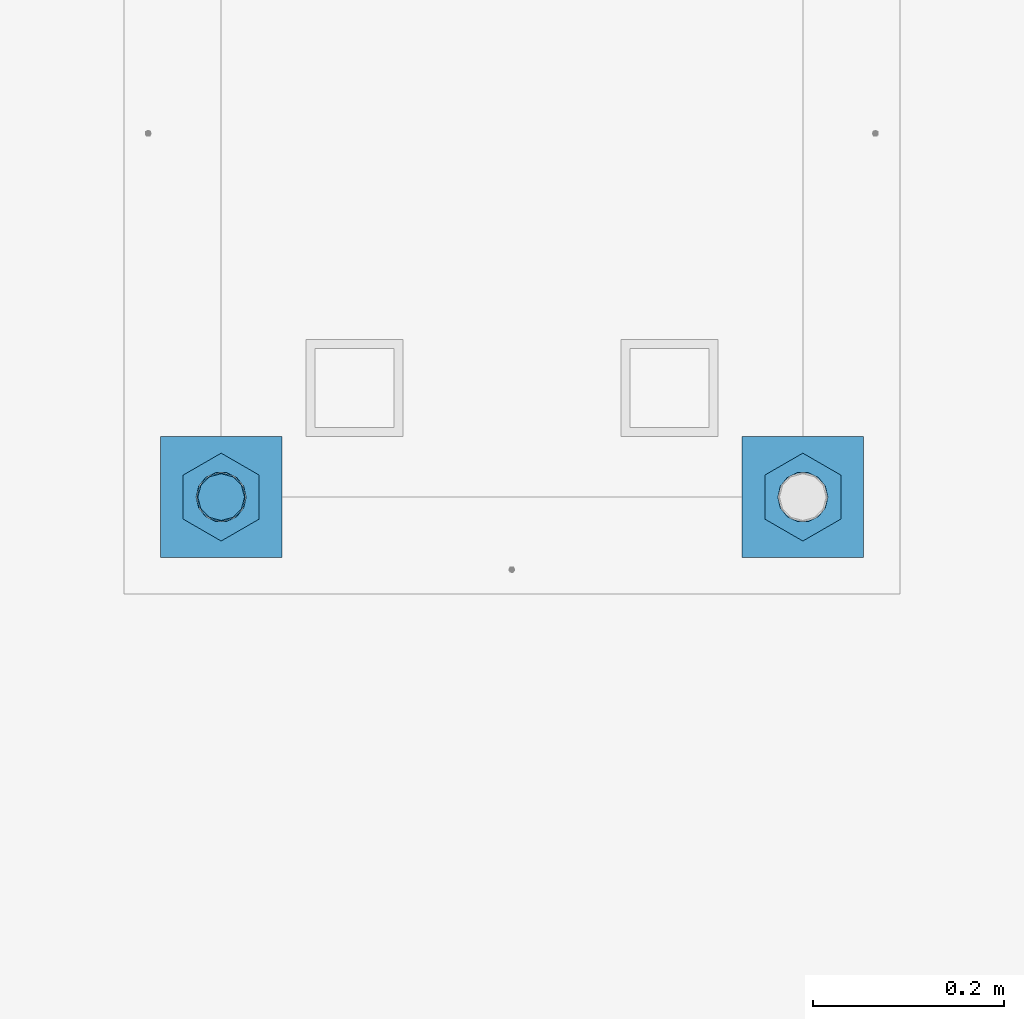
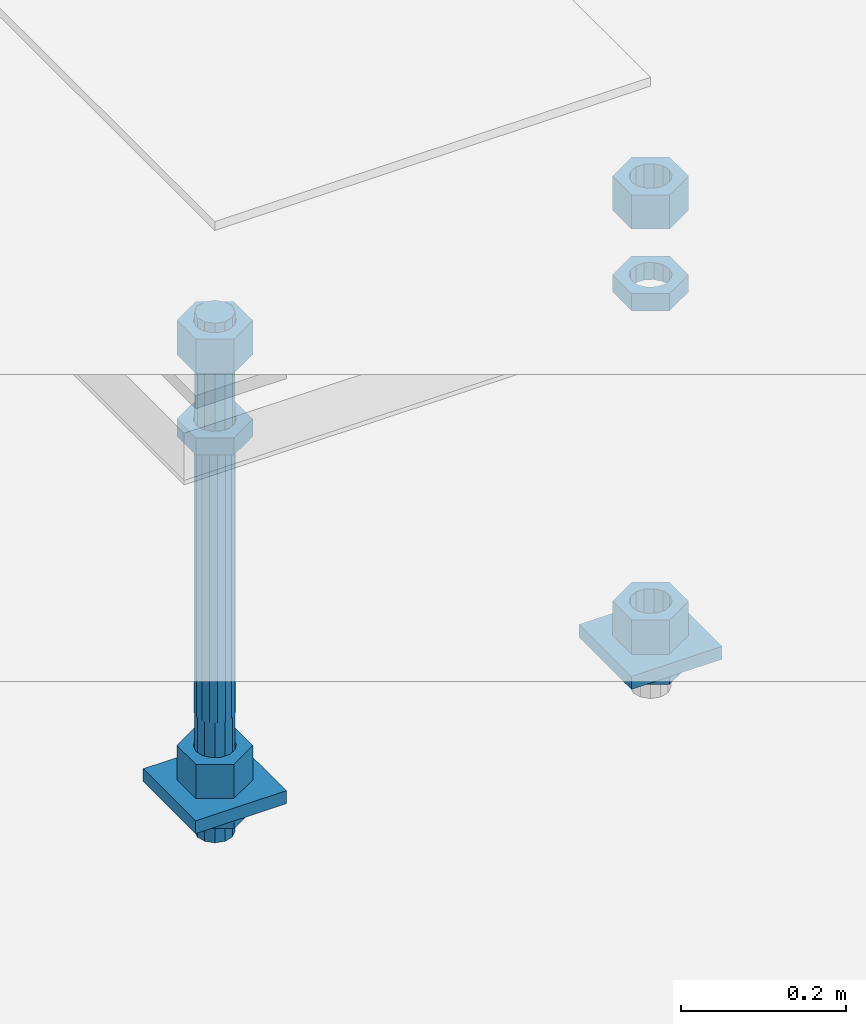
# One storey, part 2628 of 3843: 11 beams, 1 element without a shape of its own.
"""IFC2X3 building model written with IfcOpenShell, lengths in millimetres."""

from ifc_helpers import new_model, si_unit, frame, origin_with_axes, place, context, subcontext, project, spatial, faceted_brep, material, type_object, element, aggregate, save


model = new_model("IFC2X3")

# Units and contexts
model_context = context("Model", 3, precision=1e-05, world=origin_with_axes())
body_context = subcontext(model_context, "Body", "Model", "MODEL_VIEW")
ifc_project = project(units=[si_unit("LENGTHUNIT", "METRE", prefix="MILLI"), si_unit("AREAUNIT", "SQUARE_METRE"), si_unit("VOLUMEUNIT", "CUBIC_METRE"), si_unit("MASSUNIT", "GRAM", prefix="KILO"), si_unit("TIMEUNIT", "SECOND"), si_unit("PLANEANGLEUNIT", "RADIAN"), si_unit("SOLIDANGLEUNIT", "STERADIAN"), si_unit("THERMODYNAMICTEMPERATUREUNIT", "DEGREE_CELSIUS"), si_unit("LUMINOUSINTENSITYUNIT", "LUMEN")], contexts=[model_context])

# Site, building, storey
site_placement = place(None, origin_with_axes())
site = spatial("IfcSite", under=ifc_project, at=site_placement, CompositionType="ELEMENT")
building_placement = place(site_placement, origin_with_axes())
building = spatial("IfcBuilding", under=site, at=building_placement, Name="Undefined", CompositionType="ELEMENT")
storey_placement = place(building_placement, origin_with_axes())
storey = spatial("IfcBuildingStorey", under=building, at=storey_placement, Name="Undefined", CompositionType="ELEMENT", Elevation=0.0)

# Assembly, beams
assembly_placement = place(storey_placement, origin_with_axes())
assembly = element("IfcElementAssembly", 1, at=assembly_placement, inside=storey, Name="TEMPLATE", AssemblyPlace="NOTDEFINED", PredefinedType="RIGID_FRAME")
ifc_material_1 = material(Name="STEEL/A36")
beam_type_1 = type_object("IfcBeamType", PredefinedType="NOTDEFINED")
beam_1_placement = place(assembly_placement, frame((115862.099998474, 7073.90000000001, 29244.925), z_axis=(0.0, 1.0, 0.0), x_axis=(-1.0, 0.0, 0.0)))
beam_1 = element("IfcBeam", 2, at=beam_1_placement, type_object=beam_type_1, material=ifc_material_1, Name="WASHER_PLATE", context=body_context, shape_type="Brep", body=[
    faceted_brep([(0.0, 9.52500000000146, -63.5), (0.0, 9.52500000000146, 63.5), (127.0, 9.52500000000146, 63.5), (127.0, 9.52500000000146, -63.5), (0.0, -9.52500000000146, 63.5), (127.0, -9.52500000000146, 63.5), (0.0, -9.52500000000146, -63.5), (127.0, -9.52500000000146, -63.5)], [[[0, 1, 2, 3]], [[1, 4, 5, 2]], [[4, 6, 7, 5]], [[6, 0, 3, 7]], [[5, 7, 3, 2]], [[6, 4, 1, 0]]]),
])
beam_2_placement = place(assembly_placement, frame((116471.7, 7073.90000000001, 29244.925), z_axis=(0.0, 1.0, 0.0), x_axis=(-1.0, 0.0, 0.0)))
beam_2 = element("IfcBeam", 3, at=beam_2_placement, type_object=beam_type_1, material=ifc_material_1, Name="WASHER_PLATE", context=body_context, shape_type="Brep", body=[
    faceted_brep([(0.0, 9.52500000000146, -63.5), (0.0, 9.52500000000146, 63.5), (127.0, 9.52500000000146, 63.5), (127.0, 9.52500000000146, -63.5), (0.0, -9.52500000000146, 63.5), (127.0, -9.52500000000146, 63.5), (0.0, -9.52500000000146, -63.5), (127.0, -9.52500000000146, -63.5)], [[[0, 1, 2, 3]], [[1, 4, 5, 2]], [[4, 6, 7, 5]], [[6, 0, 3, 7]], [[5, 7, 3, 2]], [[6, 4, 1, 0]]]),
])
beam_type_2 = type_object("IfcBeamType", Name="2_HALF_NUT", PredefinedType="NOTDEFINED")
beam_3_placement = place(assembly_placement, frame((115798.599998474, 7073.90000000001, 29787.85), z_axis=(-1.0, 0.0, 0.0), x_axis=(0.0, 0.0, -1.0)))
beam_3 = element("IfcBeam", 4, at=beam_3_placement, type_object=beam_type_2, material=ifc_material_1, Name="NUT", ObjectType="2_HALF_NUT", context=body_context, shape_type="Brep", body=[
    faceted_brep([(0.0, -46.0369987487793, 0.0), (0.0, -23.0184993743896, -39.869213104248), (25.4000000000015, -23.0184993743896, -39.869213104248), (25.4000000000015, -46.0369987487793, 0.0), (0.0, 23.0184993743896, -39.869213104248), (25.4000000000015, 23.0184993743896, -39.869213104248), (0.0, 46.0369987487793, 0.0), (25.4000000000015, 46.0369987487793, 0.0), (0.0, 23.0184993743896, 39.869213104248), (25.4000000000015, 23.0184993743896, 39.869213104248), (0.0, -23.0184993743896, 39.869213104248), (25.4000000000015, -23.0184993743896, 39.869213104248), (0.0, 0.0, 26.1940002441406), (0.0, 11.3650617044477, 23.5999013092805), (25.4000000000015, 11.3650617044477, 23.5999013092805), (25.4000000000015, 0.0, 26.1940002441406), (0.0, 20.4791109456419, 16.3316083006721), (25.4000000000015, 20.4791109456419, 16.3316083006721), (0.0, 25.5370200498292, 5.82867859874386), (25.4000000000015, 25.5370200498292, 5.82867859874386), (0.0, 25.5370200498292, -5.82867859874386), (25.4000000000015, 25.5370200498292, -5.82867859874386), (0.0, 20.4791109456419, -16.3316083006721), (25.4000000000015, 20.4791109456419, -16.3316083006721), (0.0, 11.3650617044477, -23.5999013092805), (25.4000000000015, 11.3650617044477, -23.5999013092805), (0.0, 0.0, -26.1940002441406), (25.4000000000015, 0.0, -26.1940002441406), (0.0, -11.3650617044477, -23.5999013092805), (25.4000000000015, -11.3650617044477, -23.5999013092805), (0.0, -20.4791109456419, -16.3316083006721), (25.4000000000015, -20.4791109456419, -16.3316083006721), (0.0, -25.5370200498292, -5.82867859874386), (25.4000000000015, -25.5370200498292, -5.82867859874386), (0.0, -25.5370200498292, 5.82867859874386), (25.4000000000015, -25.5370200498292, 5.82867859874386), (0.0, -20.4791109456419, 16.3316083006721), (25.4000000000015, -20.4791109456419, 16.3316083006721), (0.0, -11.3650617044477, 23.5999013092805), (25.4000000000015, -11.3650617044477, 23.5999013092805)], [[[0, 1, 2, 3]], [[1, 4, 5, 2]], [[4, 6, 7, 5]], [[6, 8, 9, 7]], [[8, 10, 11, 9]], [[10, 0, 3, 11]], [[12, 13, 14, 15]], [[13, 16, 17, 14]], [[16, 18, 19, 17]], [[18, 20, 21, 19]], [[20, 22, 23, 21]], [[22, 24, 25, 23]], [[24, 26, 27, 25]], [[26, 28, 29, 27]], [[28, 30, 31, 29]], [[30, 32, 33, 31]], [[32, 34, 35, 33]], [[34, 36, 37, 35]], [[36, 38, 39, 37]], [[38, 12, 15, 39]], [[5, 7, 9, 11, 3, 2], [17, 19, 21, 23, 25, 27, 29, 31, 33, 35, 37, 39, 15, 14]], [[10, 8, 6, 4, 1, 0], [38, 36, 34, 32, 30, 28, 26, 24, 22, 20, 18, 16, 13, 12]]]),
])
beam_4_placement = place(assembly_placement, frame((115798.599998474, 7073.9, 29235.4), z_axis=(-1.0, 0.0, 0.0), x_axis=(0.0, 0.0, -1.0)))
beam_4 = element("IfcBeam", 5, at=beam_4_placement, type_object=beam_type_2, material=ifc_material_1, Name="NUT", ObjectType="2_HALF_NUT", context=body_context, shape_type="Brep", body=[
    faceted_brep([(0.0, -46.0369987487793, 0.0), (0.0, -23.0184993743896, -39.869213104248), (25.4000000000015, -23.0184993743896, -39.869213104248), (25.4000000000015, -46.0369987487793, 0.0), (0.0, 23.0184993743896, -39.869213104248), (25.4000000000015, 23.0184993743896, -39.869213104248), (0.0, 46.0369987487793, 0.0), (25.4000000000015, 46.0369987487793, 0.0), (0.0, 23.0184993743896, 39.869213104248), (25.4000000000015, 23.0184993743896, 39.869213104248), (0.0, -23.0184993743896, 39.869213104248), (25.4000000000015, -23.0184993743896, 39.869213104248), (0.0, 0.0, 26.1940002441406), (0.0, 11.3650617044477, 23.5999013092805), (25.4000000000015, 11.3650617044477, 23.5999013092805), (25.4000000000015, 0.0, 26.1940002441406), (0.0, 20.4791109456419, 16.3316083006721), (25.4000000000015, 20.4791109456419, 16.3316083006721), (0.0, 25.5370200498292, 5.82867859874386), (25.4000000000015, 25.5370200498292, 5.82867859874386), (0.0, 25.5370200498292, -5.82867859874386), (25.4000000000015, 25.5370200498292, -5.82867859874386), (0.0, 20.4791109456419, -16.3316083006721), (25.4000000000015, 20.4791109456419, -16.3316083006721), (0.0, 11.3650617044477, -23.5999013092805), (25.4000000000015, 11.3650617044477, -23.5999013092805), (0.0, 0.0, -26.1940002441406), (25.4000000000015, 0.0, -26.1940002441406), (0.0, -11.3650617044477, -23.5999013092805), (25.4000000000015, -11.3650617044477, -23.5999013092805), (0.0, -20.4791109456419, -16.3316083006721), (25.4000000000015, -20.4791109456419, -16.3316083006721), (0.0, -25.5370200498292, -5.82867859874386), (25.4000000000015, -25.5370200498292, -5.82867859874386), (0.0, -25.5370200498292, 5.82867859874386), (25.4000000000015, -25.5370200498292, 5.82867859874386), (0.0, -20.4791109456419, 16.3316083006721), (25.4000000000015, -20.4791109456419, 16.3316083006721), (0.0, -11.3650617044477, 23.5999013092805), (25.4000000000015, -11.3650617044477, 23.5999013092805)], [[[0, 1, 2, 3]], [[1, 4, 5, 2]], [[4, 6, 7, 5]], [[6, 8, 9, 7]], [[8, 10, 11, 9]], [[10, 0, 3, 11]], [[12, 13, 14, 15]], [[13, 16, 17, 14]], [[16, 18, 19, 17]], [[18, 20, 21, 19]], [[20, 22, 23, 21]], [[22, 24, 25, 23]], [[24, 26, 27, 25]], [[26, 28, 29, 27]], [[28, 30, 31, 29]], [[30, 32, 33, 31]], [[32, 34, 35, 33]], [[34, 36, 37, 35]], [[36, 38, 39, 37]], [[38, 12, 15, 39]], [[5, 7, 9, 11, 3, 2], [17, 19, 21, 23, 25, 27, 29, 31, 33, 35, 37, 39, 15, 14]], [[10, 8, 6, 4, 1, 0], [38, 36, 34, 32, 30, 28, 26, 24, 22, 20, 18, 16, 13, 12]]]),
])
beam_5_placement = place(assembly_placement, frame((116408.2, 7073.90000000001, 29787.85), z_axis=(-1.0, 0.0, 0.0), x_axis=(0.0, 0.0, -1.0)))
beam_5 = element("IfcBeam", 6, at=beam_5_placement, type_object=beam_type_2, material=ifc_material_1, Name="NUT", ObjectType="2_HALF_NUT", context=body_context, shape_type="Brep", body=[
    faceted_brep([(0.0, -46.0369987487793, 0.0), (0.0, -23.0184993743896, -39.869213104248), (25.4000000000015, -23.0184993743896, -39.869213104248), (25.4000000000015, -46.0369987487793, 0.0), (0.0, 23.0184993743896, -39.869213104248), (25.4000000000015, 23.0184993743896, -39.869213104248), (0.0, 46.0369987487793, 0.0), (25.4000000000015, 46.0369987487793, 0.0), (0.0, 23.0184993743896, 39.869213104248), (25.4000000000015, 23.0184993743896, 39.869213104248), (0.0, -23.0184993743896, 39.869213104248), (25.4000000000015, -23.0184993743896, 39.869213104248), (0.0, 0.0, 26.1940002441406), (0.0, 11.3650617044477, 23.5999013092805), (25.4000000000015, 11.3650617044477, 23.5999013092805), (25.4000000000015, 0.0, 26.1940002441406), (0.0, 20.4791109456419, 16.3316083006721), (25.4000000000015, 20.4791109456419, 16.3316083006721), (0.0, 25.5370200498292, 5.82867859874386), (25.4000000000015, 25.5370200498292, 5.82867859874386), (0.0, 25.5370200498292, -5.82867859874386), (25.4000000000015, 25.5370200498292, -5.82867859874386), (0.0, 20.4791109456419, -16.3316083006721), (25.4000000000015, 20.4791109456419, -16.3316083006721), (0.0, 11.3650617044477, -23.5999013092805), (25.4000000000015, 11.3650617044477, -23.5999013092805), (0.0, 0.0, -26.1940002441406), (25.4000000000015, 0.0, -26.1940002441406), (0.0, -11.3650617044477, -23.5999013092805), (25.4000000000015, -11.3650617044477, -23.5999013092805), (0.0, -20.4791109456419, -16.3316083006721), (25.4000000000015, -20.4791109456419, -16.3316083006721), (0.0, -25.5370200498292, -5.82867859874386), (25.4000000000015, -25.5370200498292, -5.82867859874386), (0.0, -25.5370200498292, 5.82867859874386), (25.4000000000015, -25.5370200498292, 5.82867859874386), (0.0, -20.4791109456419, 16.3316083006721), (25.4000000000015, -20.4791109456419, 16.3316083006721), (0.0, -11.3650617044477, 23.5999013092805), (25.4000000000015, -11.3650617044477, 23.5999013092805)], [[[0, 1, 2, 3]], [[1, 4, 5, 2]], [[4, 6, 7, 5]], [[6, 8, 9, 7]], [[8, 10, 11, 9]], [[10, 0, 3, 11]], [[12, 13, 14, 15]], [[13, 16, 17, 14]], [[16, 18, 19, 17]], [[18, 20, 21, 19]], [[20, 22, 23, 21]], [[22, 24, 25, 23]], [[24, 26, 27, 25]], [[26, 28, 29, 27]], [[28, 30, 31, 29]], [[30, 32, 33, 31]], [[32, 34, 35, 33]], [[34, 36, 37, 35]], [[36, 38, 39, 37]], [[38, 12, 15, 39]], [[5, 7, 9, 11, 3, 2], [17, 19, 21, 23, 25, 27, 29, 31, 33, 35, 37, 39, 15, 14]], [[10, 8, 6, 4, 1, 0], [38, 36, 34, 32, 30, 28, 26, 24, 22, 20, 18, 16, 13, 12]]]),
])
beam_6_placement = place(assembly_placement, frame((116408.2, 7073.9, 29235.4), z_axis=(-1.0, 0.0, 0.0), x_axis=(0.0, 0.0, -1.0)))
beam_6 = element("IfcBeam", 7, at=beam_6_placement, type_object=beam_type_2, material=ifc_material_1, Name="NUT", ObjectType="2_HALF_NUT", context=body_context, shape_type="Brep", body=[
    faceted_brep([(0.0, -46.0369987487793, 0.0), (0.0, -23.0184993743896, -39.869213104248), (25.4000000000015, -23.0184993743896, -39.869213104248), (25.4000000000015, -46.0369987487793, 0.0), (0.0, 23.0184993743896, -39.869213104248), (25.4000000000015, 23.0184993743896, -39.869213104248), (0.0, 46.0369987487793, 0.0), (25.4000000000015, 46.0369987487793, 0.0), (0.0, 23.0184993743896, 39.869213104248), (25.4000000000015, 23.0184993743896, 39.869213104248), (0.0, -23.0184993743896, 39.869213104248), (25.4000000000015, -23.0184993743896, 39.869213104248), (0.0, 0.0, 26.1940002441406), (0.0, 11.3650617044477, 23.5999013092805), (25.4000000000015, 11.3650617044477, 23.5999013092805), (25.4000000000015, 0.0, 26.1940002441406), (0.0, 20.4791109456419, 16.3316083006721), (25.4000000000015, 20.4791109456419, 16.3316083006721), (0.0, 25.5370200498292, 5.82867859874386), (25.4000000000015, 25.5370200498292, 5.82867859874386), (0.0, 25.5370200498292, -5.82867859874386), (25.4000000000015, 25.5370200498292, -5.82867859874386), (0.0, 20.4791109456419, -16.3316083006721), (25.4000000000015, 20.4791109456419, -16.3316083006721), (0.0, 11.3650617044477, -23.5999013092805), (25.4000000000015, 11.3650617044477, -23.5999013092805), (0.0, 0.0, -26.1940002441406), (25.4000000000015, 0.0, -26.1940002441406), (0.0, -11.3650617044477, -23.5999013092805), (25.4000000000015, -11.3650617044477, -23.5999013092805), (0.0, -20.4791109456419, -16.3316083006721), (25.4000000000015, -20.4791109456419, -16.3316083006721), (0.0, -25.5370200498292, -5.82867859874386), (25.4000000000015, -25.5370200498292, -5.82867859874386), (0.0, -25.5370200498292, 5.82867859874386), (25.4000000000015, -25.5370200498292, 5.82867859874386), (0.0, -20.4791109456419, 16.3316083006721), (25.4000000000015, -20.4791109456419, 16.3316083006721), (0.0, -11.3650617044477, 23.5999013092805), (25.4000000000015, -11.3650617044477, 23.5999013092805)], [[[0, 1, 2, 3]], [[1, 4, 5, 2]], [[4, 6, 7, 5]], [[6, 8, 9, 7]], [[8, 10, 11, 9]], [[10, 0, 3, 11]], [[12, 13, 14, 15]], [[13, 16, 17, 14]], [[16, 18, 19, 17]], [[18, 20, 21, 19]], [[20, 22, 23, 21]], [[22, 24, 25, 23]], [[24, 26, 27, 25]], [[26, 28, 29, 27]], [[28, 30, 31, 29]], [[30, 32, 33, 31]], [[32, 34, 35, 33]], [[34, 36, 37, 35]], [[36, 38, 39, 37]], [[38, 12, 15, 39]], [[5, 7, 9, 11, 3, 2], [17, 19, 21, 23, 25, 27, 29, 31, 33, 35, 37, 39, 15, 14]], [[10, 8, 6, 4, 1, 0], [38, 36, 34, 32, 30, 28, 26, 24, 22, 20, 18, 16, 13, 12]]]),
])
beam_type_3 = type_object("IfcBeamType", Name="2_HEAVY_HEX_NUT", PredefinedType="NOTDEFINED")
beam_7_placement = place(assembly_placement, frame((115798.599998474, 7073.90000000001, 29933.9), z_axis=(-1.0, 0.0, 0.0), x_axis=(0.0, 0.0, -1.0)))
beam_7 = element("IfcBeam", 8, at=beam_7_placement, type_object=beam_type_3, material=ifc_material_1, Name="NUT", ObjectType="2_HEAVY_HEX_NUT", context=body_context, shape_type="Brep", body=[
    faceted_brep([(0.0, -46.0369987487793, 0.0), (0.0, -23.0184993743896, -39.869213104248), (50.7999999999993, -23.0184993743896, -39.869213104248), (50.7999999999993, -46.0369987487793, 0.0), (0.0, 23.0184993743896, -39.869213104248), (50.7999999999993, 23.0184993743896, -39.869213104248), (0.0, 46.0369987487793, 0.0), (50.7999999999993, 46.0369987487793, 0.0), (0.0, 23.0184993743896, 39.869213104248), (50.7999999999993, 23.0184993743896, 39.869213104248), (0.0, -23.0184993743896, 39.869213104248), (50.7999999999993, -23.0184993743896, 39.869213104248), (0.0, 0.0, 26.1940002441406), (0.0, 11.3650617044477, 23.5999013092805), (50.7999999999993, 11.3650617044477, 23.5999013092805), (50.7999999999993, 0.0, 26.1940002441406), (0.0, 20.4791109456419, 16.3316083006721), (50.7999999999993, 20.4791109456419, 16.3316083006721), (0.0, 25.5370200498292, 5.82867859874386), (50.7999999999993, 25.5370200498292, 5.82867859874386), (0.0, 25.5370200498292, -5.82867859874386), (50.7999999999993, 25.5370200498292, -5.82867859874386), (0.0, 20.4791109456419, -16.3316083006721), (50.7999999999993, 20.4791109456419, -16.3316083006721), (0.0, 11.3650617044477, -23.5999013092805), (50.7999999999993, 11.3650617044477, -23.5999013092805), (0.0, 0.0, -26.1940002441406), (50.7999999999993, 0.0, -26.1940002441406), (0.0, -11.3650617044477, -23.5999013092805), (50.7999999999993, -11.3650617044477, -23.5999013092805), (0.0, -20.4791109456419, -16.3316083006721), (50.7999999999993, -20.4791109456419, -16.3316083006721), (0.0, -25.5370200498292, -5.82867859874386), (50.7999999999993, -25.5370200498292, -5.82867859874386), (0.0, -25.5370200498292, 5.82867859874386), (50.7999999999993, -25.5370200498292, 5.82867859874386), (0.0, -20.4791109456419, 16.3316083006721), (50.7999999999993, -20.4791109456419, 16.3316083006721), (0.0, -11.3650617044477, 23.5999013092805), (50.7999999999993, -11.3650617044477, 23.5999013092805)], [[[0, 1, 2, 3]], [[1, 4, 5, 2]], [[4, 6, 7, 5]], [[6, 8, 9, 7]], [[8, 10, 11, 9]], [[10, 0, 3, 11]], [[12, 13, 14, 15]], [[13, 16, 17, 14]], [[16, 18, 19, 17]], [[18, 20, 21, 19]], [[20, 22, 23, 21]], [[22, 24, 25, 23]], [[24, 26, 27, 25]], [[26, 28, 29, 27]], [[28, 30, 31, 29]], [[30, 32, 33, 31]], [[32, 34, 35, 33]], [[34, 36, 37, 35]], [[36, 38, 39, 37]], [[38, 12, 15, 39]], [[5, 7, 9, 11, 3, 2], [17, 19, 21, 23, 25, 27, 29, 31, 33, 35, 37, 39, 15, 14]], [[10, 8, 6, 4, 1, 0], [38, 36, 34, 32, 30, 28, 26, 24, 22, 20, 18, 16, 13, 12]]]),
])
beam_8_placement = place(assembly_placement, frame((115798.599998474, 7073.90000000001, 29305.25), z_axis=(-1.0, 0.0, 0.0), x_axis=(0.0, 0.0, -1.0)))
beam_8 = element("IfcBeam", 9, at=beam_8_placement, type_object=beam_type_3, material=ifc_material_1, Name="NUT", ObjectType="2_HEAVY_HEX_NUT", context=body_context, shape_type="Brep", body=[
    faceted_brep([(0.0, -46.0369987487793, 0.0), (0.0, -23.0184993743896, -39.869213104248), (50.7999999999993, -23.0184993743896, -39.869213104248), (50.7999999999993, -46.0369987487793, 0.0), (0.0, 23.0184993743896, -39.869213104248), (50.7999999999993, 23.0184993743896, -39.869213104248), (0.0, 46.0369987487793, 0.0), (50.7999999999993, 46.0369987487793, 0.0), (0.0, 23.0184993743896, 39.869213104248), (50.7999999999993, 23.0184993743896, 39.869213104248), (0.0, -23.0184993743896, 39.869213104248), (50.7999999999993, -23.0184993743896, 39.869213104248), (0.0, 0.0, 26.1940002441406), (0.0, 11.3650617044477, 23.5999013092805), (50.7999999999993, 11.3650617044477, 23.5999013092805), (50.7999999999993, 0.0, 26.1940002441406), (0.0, 20.4791109456419, 16.3316083006721), (50.7999999999993, 20.4791109456419, 16.3316083006721), (0.0, 25.5370200498292, 5.82867859874386), (50.7999999999993, 25.5370200498292, 5.82867859874386), (0.0, 25.5370200498292, -5.82867859874386), (50.7999999999993, 25.5370200498292, -5.82867859874386), (0.0, 20.4791109456419, -16.3316083006721), (50.7999999999993, 20.4791109456419, -16.3316083006721), (0.0, 11.3650617044477, -23.5999013092805), (50.7999999999993, 11.3650617044477, -23.5999013092805), (0.0, 0.0, -26.1940002441406), (50.7999999999993, 0.0, -26.1940002441406), (0.0, -11.3650617044477, -23.5999013092805), (50.7999999999993, -11.3650617044477, -23.5999013092805), (0.0, -20.4791109456419, -16.3316083006721), (50.7999999999993, -20.4791109456419, -16.3316083006721), (0.0, -25.5370200498292, -5.82867859874386), (50.7999999999993, -25.5370200498292, -5.82867859874386), (0.0, -25.5370200498292, 5.82867859874386), (50.7999999999993, -25.5370200498292, 5.82867859874386), (0.0, -20.4791109456419, 16.3316083006721), (50.7999999999993, -20.4791109456419, 16.3316083006721), (0.0, -11.3650617044477, 23.5999013092805), (50.7999999999993, -11.3650617044477, 23.5999013092805)], [[[0, 1, 2, 3]], [[1, 4, 5, 2]], [[4, 6, 7, 5]], [[6, 8, 9, 7]], [[8, 10, 11, 9]], [[10, 0, 3, 11]], [[12, 13, 14, 15]], [[13, 16, 17, 14]], [[16, 18, 19, 17]], [[18, 20, 21, 19]], [[20, 22, 23, 21]], [[22, 24, 25, 23]], [[24, 26, 27, 25]], [[26, 28, 29, 27]], [[28, 30, 31, 29]], [[30, 32, 33, 31]], [[32, 34, 35, 33]], [[34, 36, 37, 35]], [[36, 38, 39, 37]], [[38, 12, 15, 39]], [[5, 7, 9, 11, 3, 2], [17, 19, 21, 23, 25, 27, 29, 31, 33, 35, 37, 39, 15, 14]], [[10, 8, 6, 4, 1, 0], [38, 36, 34, 32, 30, 28, 26, 24, 22, 20, 18, 16, 13, 12]]]),
])
beam_9_placement = place(assembly_placement, frame((116408.2, 7073.90000000001, 29933.9), z_axis=(-1.0, 0.0, 0.0), x_axis=(0.0, 0.0, -1.0)))
beam_9 = element("IfcBeam", 10, at=beam_9_placement, type_object=beam_type_3, material=ifc_material_1, Name="NUT", ObjectType="2_HEAVY_HEX_NUT", context=body_context, shape_type="Brep", body=[
    faceted_brep([(0.0, -46.0369987487793, 0.0), (0.0, -23.0184993743896, -39.869213104248), (50.7999999999993, -23.0184993743896, -39.869213104248), (50.7999999999993, -46.0369987487793, 0.0), (0.0, 23.0184993743896, -39.869213104248), (50.7999999999993, 23.0184993743896, -39.869213104248), (0.0, 46.0369987487793, 0.0), (50.7999999999993, 46.0369987487793, 0.0), (0.0, 23.0184993743896, 39.869213104248), (50.7999999999993, 23.0184993743896, 39.869213104248), (0.0, -23.0184993743896, 39.869213104248), (50.7999999999993, -23.0184993743896, 39.869213104248), (0.0, 0.0, 26.1940002441406), (0.0, 11.3650617044477, 23.5999013092805), (50.7999999999993, 11.3650617044477, 23.5999013092805), (50.7999999999993, 0.0, 26.1940002441406), (0.0, 20.4791109456419, 16.3316083006721), (50.7999999999993, 20.4791109456419, 16.3316083006721), (0.0, 25.5370200498292, 5.82867859874386), (50.7999999999993, 25.5370200498292, 5.82867859874386), (0.0, 25.5370200498292, -5.82867859874386), (50.7999999999993, 25.5370200498292, -5.82867859874386), (0.0, 20.4791109456419, -16.3316083006721), (50.7999999999993, 20.4791109456419, -16.3316083006721), (0.0, 11.3650617044477, -23.5999013092805), (50.7999999999993, 11.3650617044477, -23.5999013092805), (0.0, 0.0, -26.1940002441406), (50.7999999999993, 0.0, -26.1940002441406), (0.0, -11.3650617044477, -23.5999013092805), (50.7999999999993, -11.3650617044477, -23.5999013092805), (0.0, -20.4791109456419, -16.3316083006721), (50.7999999999993, -20.4791109456419, -16.3316083006721), (0.0, -25.5370200498292, -5.82867859874386), (50.7999999999993, -25.5370200498292, -5.82867859874386), (0.0, -25.5370200498292, 5.82867859874386), (50.7999999999993, -25.5370200498292, 5.82867859874386), (0.0, -20.4791109456419, 16.3316083006721), (50.7999999999993, -20.4791109456419, 16.3316083006721), (0.0, -11.3650617044477, 23.5999013092805), (50.7999999999993, -11.3650617044477, 23.5999013092805)], [[[0, 1, 2, 3]], [[1, 4, 5, 2]], [[4, 6, 7, 5]], [[6, 8, 9, 7]], [[8, 10, 11, 9]], [[10, 0, 3, 11]], [[12, 13, 14, 15]], [[13, 16, 17, 14]], [[16, 18, 19, 17]], [[18, 20, 21, 19]], [[20, 22, 23, 21]], [[22, 24, 25, 23]], [[24, 26, 27, 25]], [[26, 28, 29, 27]], [[28, 30, 31, 29]], [[30, 32, 33, 31]], [[32, 34, 35, 33]], [[34, 36, 37, 35]], [[36, 38, 39, 37]], [[38, 12, 15, 39]], [[5, 7, 9, 11, 3, 2], [17, 19, 21, 23, 25, 27, 29, 31, 33, 35, 37, 39, 15, 14]], [[10, 8, 6, 4, 1, 0], [38, 36, 34, 32, 30, 28, 26, 24, 22, 20, 18, 16, 13, 12]]]),
])
beam_10_placement = place(assembly_placement, frame((116408.2, 7073.90000000001, 29305.25), z_axis=(-1.0, 0.0, 0.0), x_axis=(0.0, 0.0, -1.0)))
beam_10 = element("IfcBeam", 11, at=beam_10_placement, type_object=beam_type_3, material=ifc_material_1, Name="NUT", ObjectType="2_HEAVY_HEX_NUT", context=body_context, shape_type="Brep", body=[
    faceted_brep([(0.0, -46.0369987487793, 0.0), (0.0, -23.0184993743896, -39.869213104248), (50.7999999999993, -23.0184993743896, -39.869213104248), (50.7999999999993, -46.0369987487793, 0.0), (0.0, 23.0184993743896, -39.869213104248), (50.7999999999993, 23.0184993743896, -39.869213104248), (0.0, 46.0369987487793, 0.0), (50.7999999999993, 46.0369987487793, 0.0), (0.0, 23.0184993743896, 39.869213104248), (50.7999999999993, 23.0184993743896, 39.869213104248), (0.0, -23.0184993743896, 39.869213104248), (50.7999999999993, -23.0184993743896, 39.869213104248), (0.0, 0.0, 26.1940002441406), (0.0, 11.3650617044477, 23.5999013092805), (50.7999999999993, 11.3650617044477, 23.5999013092805), (50.7999999999993, 0.0, 26.1940002441406), (0.0, 20.4791109456419, 16.3316083006721), (50.7999999999993, 20.4791109456419, 16.3316083006721), (0.0, 25.5370200498292, 5.82867859874386), (50.7999999999993, 25.5370200498292, 5.82867859874386), (0.0, 25.5370200498292, -5.82867859874386), (50.7999999999993, 25.5370200498292, -5.82867859874386), (0.0, 20.4791109456419, -16.3316083006721), (50.7999999999993, 20.4791109456419, -16.3316083006721), (0.0, 11.3650617044477, -23.5999013092805), (50.7999999999993, 11.3650617044477, -23.5999013092805), (0.0, 0.0, -26.1940002441406), (50.7999999999993, 0.0, -26.1940002441406), (0.0, -11.3650617044477, -23.5999013092805), (50.7999999999993, -11.3650617044477, -23.5999013092805), (0.0, -20.4791109456419, -16.3316083006721), (50.7999999999993, -20.4791109456419, -16.3316083006721), (0.0, -25.5370200498292, -5.82867859874386), (50.7999999999993, -25.5370200498292, -5.82867859874386), (0.0, -25.5370200498292, 5.82867859874386), (50.7999999999993, -25.5370200498292, 5.82867859874386), (0.0, -20.4791109456419, 16.3316083006721), (50.7999999999993, -20.4791109456419, 16.3316083006721), (0.0, -11.3650617044477, 23.5999013092805), (50.7999999999993, -11.3650617044477, 23.5999013092805)], [[[0, 1, 2, 3]], [[1, 4, 5, 2]], [[4, 6, 7, 5]], [[6, 8, 9, 7]], [[8, 10, 11, 9]], [[10, 0, 3, 11]], [[12, 13, 14, 15]], [[13, 16, 17, 14]], [[16, 18, 19, 17]], [[18, 20, 21, 19]], [[20, 22, 23, 21]], [[22, 24, 25, 23]], [[24, 26, 27, 25]], [[26, 28, 29, 27]], [[28, 30, 31, 29]], [[30, 32, 33, 31]], [[32, 34, 35, 33]], [[34, 36, 37, 35]], [[36, 38, 39, 37]], [[38, 12, 15, 39]], [[5, 7, 9, 11, 3, 2], [17, 19, 21, 23, 25, 27, 29, 31, 33, 35, 37, 39, 15, 14]], [[10, 8, 6, 4, 1, 0], [38, 36, 34, 32, 30, 28, 26, 24, 22, 20, 18, 16, 13, 12]]]),
])
ifc_material_2 = material()
beam_type_4 = type_object("IfcBeamType", PredefinedType="NOTDEFINED")
beam_11_placement = place(assembly_placement, frame((115798.599998474, 7073.90000000001, 29762.45), z_axis=(-1.0, 0.0, 0.0), x_axis=(0.0, 0.0, -1.0)))
beam_11 = element("IfcBeam", 12, at=beam_11_placement, type_object=beam_type_4, material=ifc_material_2, Name="ANCHOR_ROD", context=body_context, shape_type="Brep", body=[
    faceted_brep([(-184.150000000001, -21.217622392709, 12.25), (-184.150000000001, -12.2499999999854, 21.2176223927163), (-184.150000000001, 1.45519152283669e-11, 24.5), (-184.150000000001, 12.2500000000146, 21.2176223927163), (-184.150000000001, 21.2176223927381, 12.25), (-184.150000000001, 24.5000000000146, 0.0), (-184.150000000001, 21.2176223927381, -12.25), (-184.150000000001, 12.2500000000146, -21.2176223927163), (-184.150000000001, 1.45519152283669e-11, -24.5), (-184.150000000001, -12.2499999999854, -21.2176223927163), (-184.150000000001, -21.217622392709, -12.25), (-184.150000000001, -24.4999999999854, 0.0), (0.0, 24.5000000000146, 0.0), (0.0, 21.2176223927381, -12.25), (0.0, 12.2500000000146, -21.2176223927163), (0.0, 1.45519152283669e-11, -24.5), (0.0, -12.2499999999854, -21.2176223927163), (0.0, -21.217622392709, -12.25), (0.0, -24.4999999999854, 0.0), (0.0, -21.217622392709, 12.25), (0.0, -12.2499999999854, 21.2176223927163), (0.0, 1.45519152283669e-11, 24.5), (0.0, 12.2500000000146, 21.2176223927163), (0.0, 21.2176223927381, 12.25), (0.0, -23.4665401257807, 9.72015918207035), (0.0, -17.9605122421344, 17.9605122421417), (0.0, -9.72015918207762, 23.466540125788), (0.0, 0.0, 25.4000000000015), (0.0, 9.72015918207762, 23.466540125788), (0.0, 17.9605122421344, 17.9605122421417), (0.0, 23.4665401257807, 9.72015918207035), (0.0, 25.3999996185303, 0.0), (0.0, 23.4665401257807, -9.72015918207035), (0.0, 17.9605122421344, -17.9605122421417), (0.0, 9.72015918207762, -23.466540125788), (0.0, 0.0, -25.4000000000015), (0.0, -9.72015918207762, -23.466540125788), (0.0, -17.9605122421344, -17.9605122421417), (0.0, -23.4665401257807, -9.72015918207035), (0.0, -25.3999996185303, 0.0), (406.399999999998, -25.3999999999942, 0.0), (406.399999999998, -23.4665401257807, 9.72015918207035), (406.399999999998, -17.9605122421344, 17.9605122421417), (406.399999999998, -9.72015918207762, 23.466540125788), (406.399999999998, 0.0, 25.4000000000015), (406.399999999998, 9.72015918207762, 23.466540125788), (406.399999999998, 17.9605122421344, 17.9605122421417), (406.399999999998, 23.4665401257807, 9.72015918207035), (406.399999999998, 25.3999999999942, 0.0), (406.399999999998, 23.4665401257807, -9.72015918207035), (406.399999999998, 17.9605122421344, -17.9605122421417), (406.399999999998, 9.72015918207762, -23.466540125788), (406.399999999998, 0.0, -25.4000000000015), (406.399999999998, -9.72015918207762, -23.466540125788), (406.399999999998, -17.9605122421344, -17.9605122421417), (406.399999999998, -23.4665401257807, -9.72015918207035), (406.399999999998, -12.2499999999854, 21.2176223927163), (406.399999999998, 1.45519152283669e-11, 24.5), (406.399999999998, 12.2500000000146, 21.2176223927163), (406.399999999998, 21.2176223927381, 12.25), (406.399999999998, 24.5000000000146, 0.0), (406.399999999998, 21.2176223927381, -12.25), (406.399999999998, 12.2500000000146, -21.2176223927163), (406.399999999998, 1.45519152283669e-11, -24.5), (406.399999999998, -12.2499999999854, -21.2176223927163), (406.399999999998, -21.217622392709, -12.25), (406.399999999998, -24.4999999999854, 0.0), (406.399999999998, -21.217622392709, 12.25), (584.200000000001, -12.2499999999854, -21.2176223927163), (584.200000000001, 1.45519152283669e-11, -24.5), (584.200000000001, 12.2500000000146, -21.2176223927163), (584.200000000001, 21.2176223927381, -12.25), (584.200000000001, 24.5000000000146, 0.0), (584.200000000001, 21.2176223927381, 12.25), (584.200000000001, 12.2500000000146, 21.2176223927163), (584.200000000001, 1.45519152283669e-11, 24.5), (584.200000000001, -12.2499999999854, 21.2176223927163), (584.200000000001, -21.217622392709, 12.25), (584.200000000001, -24.4999999999854, 0.0), (584.200000000001, -21.217622392709, -12.25)], [[[0, 1, 2, 3, 4, 5, 6, 7, 8, 9, 10, 11]], [[6, 5, 12, 13]], [[7, 6, 13, 14]], [[8, 7, 14, 15]], [[9, 8, 15, 16]], [[10, 9, 16, 17]], [[11, 10, 17, 18]], [[0, 11, 18, 19]], [[1, 0, 19, 20]], [[2, 1, 20, 21]], [[3, 2, 21, 22]], [[4, 3, 22, 23]], [[5, 4, 23, 12]], [[24, 25, 26, 27, 28, 29, 30, 31, 32, 33, 34, 35, 36, 37, 38, 39], [22, 21, 20, 19, 18, 17, 16, 15, 14, 13, 12, 23]], [[24, 39, 40, 41]], [[25, 24, 41, 42]], [[26, 25, 42, 43]], [[27, 26, 43, 44]], [[28, 27, 44, 45]], [[29, 28, 45, 46]], [[30, 29, 46, 47]], [[31, 30, 47, 48]], [[32, 31, 48, 49]], [[33, 32, 49, 50]], [[34, 33, 50, 51]], [[35, 34, 51, 52]], [[36, 35, 52, 53]], [[37, 36, 53, 54]], [[38, 37, 54, 55]], [[39, 38, 55, 40]], [[54, 53, 52, 51, 50, 49, 48, 47, 46, 45, 44, 43, 42, 41, 40, 55], [56, 57, 58, 59, 60, 61, 62, 63, 64, 65, 66, 67]], [[68, 69, 70, 71, 72, 73, 74, 75, 76, 77, 78, 79]], [[76, 75, 57, 56]], [[77, 76, 56, 67]], [[78, 77, 67, 66]], [[79, 78, 66, 65]], [[68, 79, 65, 64]], [[69, 68, 64, 63]], [[70, 69, 63, 62]], [[71, 70, 62, 61]], [[72, 71, 61, 60]], [[73, 72, 60, 59]], [[74, 73, 59, 58]], [[75, 74, 58, 57]]]),
])
aggregate(assembly, [beam_1, beam_3, beam_7, beam_8, beam_4, beam_11, beam_2, beam_5, beam_9, beam_10, beam_6])

save(model, "model.ifc")
